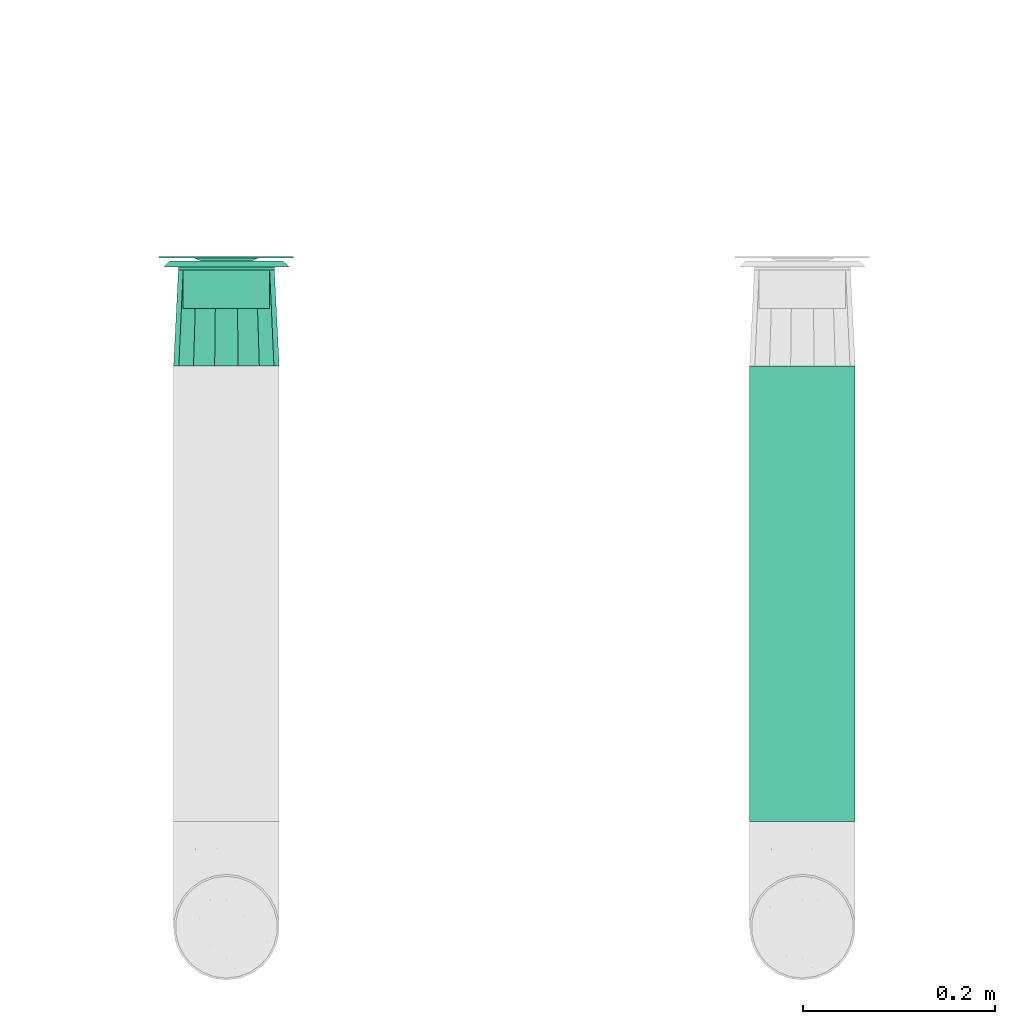
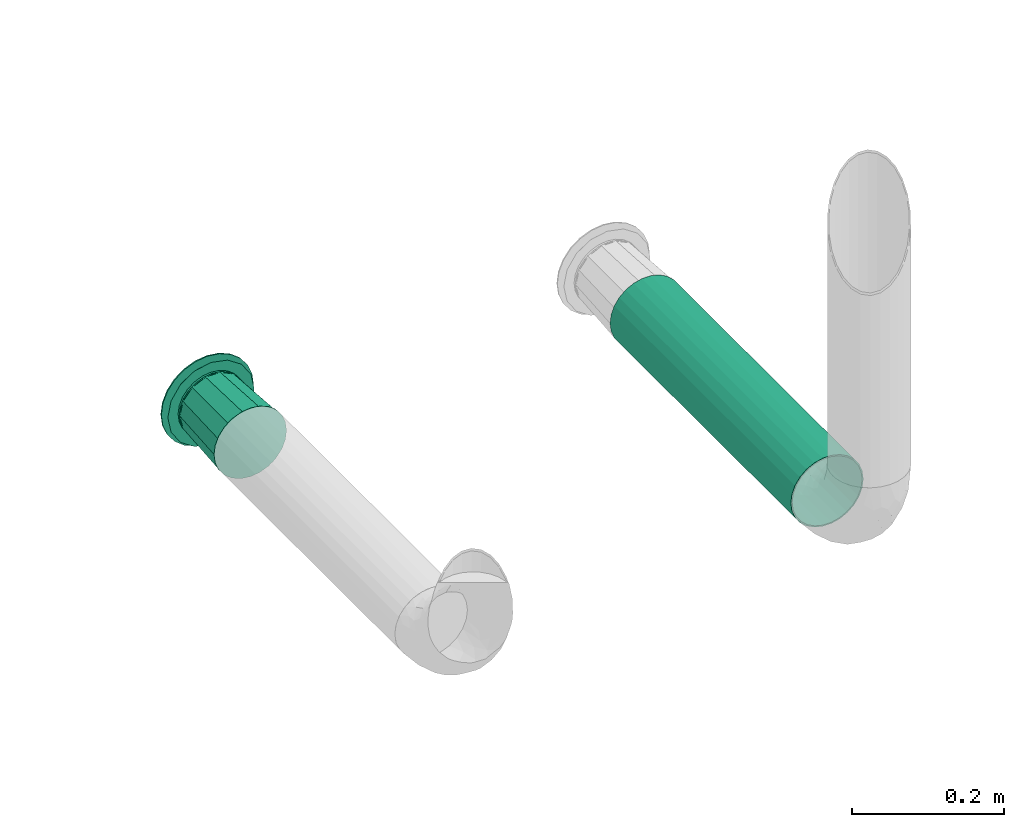
# One storey, part 24 of 115: 1 flow fitting, 1 flow segment, 1 flow terminal.
"""IFC2X3 building model written with IfcOpenShell, lengths in millimetres."""

import ifcopenshell
import ifcopenshell.guid

model = None  # the IFC model being written
_history = None  # IfcOwnerHistory: only IFC2X3 demands one
_inside = {}  # id of a spatial element -> (the spatial element, [elements in it])
_under = {}  # id of a project, library or spatial element -> (it, [spatial elements below it])
_declared = {}  # id of a project -> (the project, [libraries it declares])
_typed = {}  # id of a type object -> (the type object, [elements of that type])
_made_of = {}  # id of a material, layer set ... -> (it, [elements and type objects made of it])


def new_model(schema):
    """Start an empty IFC model of exactly this schema.

    Asked for "IFC4X3", IfcOpenShell would pick the latest addendum, in which some entities
    have other attributes; the version numbers below select the first issue.
    IFC2X3 requires an IfcOwnerHistory on every rooted entity: one is made here for all.
    """
    global model, _history
    if schema == "IFC4X3":
        model = ifcopenshell.file(schema_version=(4, 3, 0, 0))
    else:
        model = ifcopenshell.file(schema=schema)
    _inside.clear()
    _under.clear()
    _declared.clear()
    _typed.clear()
    _made_of.clear()
    _history = None
    if model.schema == "IFC2X3":
        org = make("IfcOrganization", Name="unknown")
        user = make(
            "IfcPersonAndOrganization",
            ThePerson=make("IfcPerson", FamilyName="unknown"),
            TheOrganization=org,
        )
        app = make(
            "IfcApplication",
            ApplicationDeveloper=org,
            Version="unknown",
            ApplicationFullName="unknown",
            ApplicationIdentifier="unknown",
        )
        _history = make(
            "IfcOwnerHistory",
            OwningUser=user,
            OwningApplication=app,
            ChangeAction="ADDED",
            CreationDate=0,
        )
    return model


def make(cls, **values):
    """One entity of the class cls with the attributes given. An attribute that is None is left unset."""
    return model.create_entity(
        cls, **{name: value for name, value in values.items() if value is not None}
    )


def entity(cls, *values):
    """Any entity or typed value of the class cls, its attributes in the order of the schema. None: left unset."""
    e = model.create_entity(cls)
    for i, value in enumerate(values):
        if value is not None:
            e[i] = value
    return e


def rooted(cls, **values):
    """An entity with a GlobalId (a new one), such as an element, a storey or a relation."""
    return make(cls, GlobalId=ifcopenshell.guid.new(), OwnerHistory=_history, **values)


def si_unit(unit_type, name, prefix=None):
    """IfcSIUnit, for example si_unit("LENGTHUNIT", "METRE", prefix="MILLI")."""
    return make("IfcSIUnit", UnitType=unit_type, Prefix=prefix, Name=name)


def converted_unit(unit_type, name, factor, base, dimensions=None, offset=None):
    """IfcConversionBasedUnit, such as the inch: factor (a typed value) times the base unit."""
    return make(
        "IfcConversionBasedUnit"
        if offset is None
        else "IfcConversionBasedUnitWithOffset",
        ConversionOffset=offset,
        Dimensions=None
        if dimensions is None
        else entity("IfcDimensionalExponents", *dimensions),
        UnitType=unit_type,
        Name=name,
        ConversionFactor=make(
            "IfcMeasureWithUnit", ValueComponent=factor, UnitComponent=base
        ),
    )


def derived_unit(unit_type, elements):
    """IfcDerivedUnit: a product of units, each with its exponent."""
    return make(
        "IfcDerivedUnit",
        Elements=[
            make("IfcDerivedUnitElement", Unit=unit, Exponent=power)
            for unit, power in elements
        ],
        UnitType=unit_type,
    )


def assignment(units):
    """IfcUnitAssignment: the units of a project."""
    return None if units is None else make("IfcUnitAssignment", Units=units)


def point(xyz):
    """IfcCartesianPoint."""
    return None if xyz is None else make("IfcCartesianPoint", Coordinates=xyz)


def direction(xyz):
    """IfcDirection."""
    return None if xyz is None else make("IfcDirection", DirectionRatios=xyz)


def frame(location, z_axis=None, x_axis=None):
    """IfcAxis2Placement3D, a coordinate frame: its origin and axes. An axis left out is left unset."""
    return make(
        "IfcAxis2Placement3D",
        Location=point(location),
        Axis=direction(z_axis),
        RefDirection=direction(x_axis),
    )


def frame_2d(location, x_axis=None):
    """IfcAxis2Placement2D, a coordinate frame in the plane: its origin and x axis."""
    return make(
        "IfcAxis2Placement2D", Location=point(location), RefDirection=direction(x_axis)
    )


def origin_with_axes():
    """The frame at (0, 0, 0) with the z axis (0, 0, 1) and the x axis (1, 0, 0) written out."""
    return frame((0.0, 0.0, 0.0), z_axis=(0.0, 0.0, 1.0), x_axis=(1.0, 0.0, 0.0))


def origin_2d_with_axis():
    """The frame at (0, 0) in the plane with the x axis (1, 0) written out."""
    return frame_2d((0.0, 0.0), x_axis=(1.0, 0.0))


def place(relative_to, where):
    """IfcLocalPlacement: puts the frame where relative to a parent placement (None: the world)."""
    return make(
        "IfcLocalPlacement", PlacementRelTo=relative_to, RelativePlacement=where
    )


def context(
    kind, dimensions, precision=None, world=None, true_north=None, identifier=None
):
    """IfcGeometricRepresentationContext, for example the 3D "Model" context."""
    return make(
        "IfcGeometricRepresentationContext",
        ContextIdentifier=identifier,
        ContextType=kind,
        CoordinateSpaceDimension=dimensions,
        Precision=precision,
        WorldCoordinateSystem=world,
        TrueNorth=true_north,
    )


def subcontext(parent, identifier, kind, view, scale=None):
    """IfcGeometricRepresentationSubContext, for example "Body" below "Model"."""
    return make(
        "IfcGeometricRepresentationSubContext",
        ContextIdentifier=identifier,
        ContextType=kind,
        ParentContext=parent,
        TargetScale=scale,
        TargetView=view,
    )


def project(units=None, contexts=None):
    """IfcProject with its units and contexts."""
    return rooted(
        "IfcProject",
        Name="project",
        RepresentationContexts=contexts,
        UnitsInContext=assignment(units),
    )


def spatial(cls, under=None, at=None, **own):
    """A site, building, storey or space (cls), placed at a placement, below another one or the project."""
    s = rooted(cls, ObjectPlacement=at, **own)
    if under is not None:
        _under.setdefault(under.id(), (under, []))[1].append(s)
    return s


def profile(cls, at=None, kind="AREA", **sizes):
    """A parametric profile (cls). Its sizes go by their IFC names, for example OverallWidth=200.0."""
    return make(cls, ProfileType=kind, Position=at, **sizes)


def hollow_circle(**sizes):
    """IfcCircleHollowProfileDef."""
    return profile("IfcCircleHollowProfileDef", **sizes)


def extrude(swept, where, along, depth):
    """IfcExtrudedAreaSolid: the profile swept, set in the frame where, extruded along a direction by depth."""
    return make(
        "IfcExtrudedAreaSolid",
        SweptArea=swept,
        Position=where,
        ExtrudedDirection=direction(along),
        Depth=depth,
    )


def faces_of(points, faces, orient=None, outer=None):
    """IfcFace entities. A face is a list of loops; a loop is a list of indices into points, from 0.

    orient and outer hold one flag for each loop. By default every Orientation is true, the
    first loop of a face is its IfcFaceOuterBound and the others are IfcFaceBound.
    """
    made = []
    for i, loops in enumerate(faces):
        bounds = []
        for j, loop in enumerate(loops):
            is_outer = j == 0 if outer is None else outer[i][j]
            bounds.append(
                make(
                    "IfcFaceOuterBound" if is_outer else "IfcFaceBound",
                    Bound=make("IfcPolyLoop", Polygon=[points[k] for k in loop]),
                    Orientation=True if orient is None else orient[i][j],
                )
            )
        made.append(make("IfcFace", Bounds=bounds))
    return made


def open_shell(faces, orient=None, outer=None):
    """The faces of one IfcOpenShell. surface_model builds it on its shared points."""
    return ("IfcOpenShell", faces, orient, outer)


def surface_model(cls, points, shells):
    """IfcFaceBasedSurfaceModel or IfcShellBasedSurfaceModel (cls): surfaces that need not close."""
    shared = [point(p) for p in points]
    made = [make(c, CfsFaces=faces_of(shared, fs, o, b)) for c, fs, o, b in shells]
    if cls == "IfcFaceBasedSurfaceModel":
        return make(cls, FbsmFaces=made)
    return make(cls, SbsmBoundary=made)


def shape(context_of_items, identifier, shape_type, items):
    """IfcShapeRepresentation: the items that make up one representation, for example the "Body"."""
    return make(
        "IfcShapeRepresentation",
        ContextOfItems=context_of_items,
        RepresentationIdentifier=identifier,
        RepresentationType=shape_type,
        Items=items,
    )


def source(mapping_origin, context_of_items, identifier, shape_type, items):
    """IfcRepresentationMap: a shape defined once, which mapped items show again and again."""
    return make(
        "IfcRepresentationMap",
        MappingOrigin=mapping_origin,
        MappedRepresentation=shape(context_of_items, identifier, shape_type, items),
    )


def transform(
    local_origin,
    x_axis=None,
    y_axis=None,
    z_axis=None,
    scale=None,
    scale2=None,
    scale3=None,
    uniform=True,
):
    """IfcCartesianTransformationOperator3D, or its non-uniform kind. x_axis, y_axis, z_axis: its Axis1, 2, 3."""
    if uniform:
        return make(
            "IfcCartesianTransformationOperator3D",
            Axis1=direction(x_axis),
            Axis2=direction(y_axis),
            LocalOrigin=point(local_origin),
            Scale=scale,
            Axis3=direction(z_axis),
        )
    return make(
        "IfcCartesianTransformationOperator3DnonUniform",
        Axis1=direction(x_axis),
        Axis2=direction(y_axis),
        LocalOrigin=point(local_origin),
        Scale=scale,
        Axis3=direction(z_axis),
        Scale2=scale2,
        Scale3=scale3,
    )


def mapped(mapping_source, mapping_target):
    """IfcMappedItem: shows the shape of a source again, moved by a transform."""
    return make(
        "IfcMappedItem", MappingSource=mapping_source, MappingTarget=mapping_target
    )


def material(Name=None, Category=None):
    """IfcMaterial."""
    return make("IfcMaterial", Name=Name, Category=Category)


def layer(
    of_material, thickness, ventilated=None, Name=None, Category=None, Priority=None
):
    """IfcMaterialLayer: one layer of a wall or slab, of a material (None: an air gap)."""
    return make(
        "IfcMaterialLayer",
        Material=of_material,
        LayerThickness=thickness,
        IsVentilated=ventilated,
        Name=Name,
        Category=Category,
        Priority=Priority,
    )


def layer_set(layers, Name=None):
    """IfcMaterialLayerSet."""
    return make("IfcMaterialLayerSet", MaterialLayers=layers, LayerSetName=Name)


def layer_usage(for_layer_set, set_direction, sense, offset, extent=None):
    """IfcMaterialLayerSetUsage: how a layer set lies in its element."""
    return make(
        "IfcMaterialLayerSetUsage",
        ForLayerSet=for_layer_set,
        LayerSetDirection=set_direction,
        DirectionSense=sense,
        OffsetFromReferenceLine=offset,
        ReferenceExtent=extent,
    )


def made_of(thing, what):
    """Note that an element or type object is made of a material, layer set ...; save() writes the relation."""
    if what is not None:
        _made_of.setdefault(what.id(), (what, []))[1].append(thing)
    return thing


def type_object(cls, material=None, **own):
    """A type object (cls), such as IfcWallType, which elements share."""
    return made_of(rooted(cls, **own), material)


def element(
    cls,
    number,
    at=None,
    inside=None,
    cuts=None,
    type_object=None,
    material=None,
    context=None,
    identifier="Body",
    shape_type=None,
    held_by="IfcProductDefinitionShape",
    body=None,
    shapes=None,
    **own,
):
    """One element of the class cls, such as IfcWall. Its Tag is "e" and its number.

    at: its placement. inside: the storey or other place that contains it. cuts: it is an
    opening in that element (IfcRelVoidsElement). A single representation is given by context,
    identifier, shape_type and body (its items); several are given by shapes. held_by: the class
    of the entity that holds the representations. save() writes the other relations.
    """
    e = rooted(cls, Tag="e%d" % number, ObjectPlacement=at, **own)
    if body is not None:
        shapes = [shape(context, identifier, shape_type, body)]
    if shapes is not None:
        e.Representation = make(held_by, Representations=shapes)
    if inside is not None:
        _inside.setdefault(inside.id(), (inside, []))[1].append(e)
    if cuts is not None:
        rooted(
            "IfcRelVoidsElement", RelatingBuildingElement=cuts, RelatedOpeningElement=e
        )
    if type_object is not None:
        _typed.setdefault(type_object.id(), (type_object, []))[1].append(e)
    return made_of(e, material)


def aggregate(whole, parts):
    """IfcRelAggregates: a whole, such as a stair, and the parts it consists of."""
    return rooted("IfcRelAggregates", RelatingObject=whole, RelatedObjects=parts)


def save(model, path):
    """Write the relations noted so far, then the file.

    IfcRelAggregates (storeys below a building ...), IfcRelContainedInSpatialStructure (elements
    in a storey), IfcRelDefinesByType, IfcRelAssociatesMaterial and IfcRelDeclares: one each for
    every whole, place, type object, material and project.
    """
    for whole, parts in _under.values():
        aggregate(whole, parts)
    for where, things in _inside.values():
        rooted(
            "IfcRelContainedInSpatialStructure",
            RelatedElements=things,
            RelatingStructure=where,
        )
    for kind, things in _typed.values():
        rooted("IfcRelDefinesByType", RelatedObjects=things, RelatingType=kind)
    for what, things in _made_of.values():
        rooted("IfcRelAssociatesMaterial", RelatedObjects=things, RelatingMaterial=what)
    for by, libraries in _declared.values():
        rooted("IfcRelDeclares", RelatingContext=by, RelatedDefinitions=libraries)
    model.write(path)


model = new_model("IFC2X3")

# Units and contexts
model_context = context("Model", 3, precision=1e-05, world=origin_with_axes(), true_north=direction((0.0, 1.0)))
body_context = subcontext(model_context, "Body", "Model", "MODEL_VIEW")
ifc_project = project(units=[si_unit("AREAUNIT", "SQUARE_METRE"), si_unit("VOLUMEUNIT", "CUBIC_METRE", prefix="DECI"), si_unit("TIMEUNIT", "SECOND"), si_unit("THERMODYNAMICTEMPERATUREUNIT", "DEGREE_CELSIUS"), si_unit("PRESSUREUNIT", "PASCAL"), si_unit("MASSUNIT", "GRAM", prefix="KILO"), si_unit("LENGTHUNIT", "METRE", prefix="MILLI"), si_unit("POWERUNIT", "WATT"), si_unit("ELECTRICCURRENTUNIT", "AMPERE"), si_unit("ELECTRICVOLTAGEUNIT", "VOLT"), derived_unit("VOLUMETRICFLOWRATEUNIT", [(si_unit("VOLUMEUNIT", "CUBIC_METRE", prefix="DECI"), 1), (si_unit("TIMEUNIT", "SECOND"), -1)]), derived_unit("LINEARVELOCITYUNIT", [(si_unit("LENGTHUNIT", "METRE"), 1), (si_unit("TIMEUNIT", "SECOND"), -1)]), derived_unit("MASSDENSITYUNIT", [(si_unit("MASSUNIT", "GRAM", prefix="KILO"), 1), (si_unit("VOLUMEUNIT", "CUBIC_METRE"), -1)]), converted_unit("PLANEANGLEUNIT", "DEGREE", entity("IfcRatioMeasure", 0.01745), si_unit("PLANEANGLEUNIT", "RADIAN"), dimensions=[0, 0, 0, 0, 0, 0, 0])], contexts=[model_context])

# Site, building, storey
site_placement = place(None, origin_with_axes())
site = spatial("IfcSite", under=ifc_project, at=site_placement, CompositionType="ELEMENT")
building_placement = place(site_placement, origin_with_axes())
building = spatial("IfcBuilding", under=site, at=building_placement, Name="mc-building", CompositionType="ELEMENT")
storey_placement = place(building_placement, frame((0.0, 0.0, 2950.0), z_axis=(0.0, 0.0, 1.0), x_axis=(1.0, 0.0, 0.0)))
storey = spatial("IfcBuildingStorey", under=building, at=storey_placement, Name="2. Korrus", CompositionType="ELEMENT", Elevation=2950.0)

# Flow terminal
air_terminal_type = type_object("IfcAirTerminalType", Name="100", PredefinedType="NOTDEFINED")
shared_shape_1 = source(origin_with_axes(), body_context, "Body", "SurfaceModel", [
    surface_model("IfcShellBasedSurfaceModel", [(11.2, 18.11733, -67.61481), (11.2, -18.11733, -67.61481), (11.2, 0.0, -70.0), (11.2, 67.61481, -18.11733), (11.2, 35.0, -60.62178), (11.2, 49.49747, -49.49747), (11.2, 60.62178, -35.0), (11.2, -67.61481, 18.11733), (11.2, -49.49747, -49.49747), (11.2, -67.61481, -18.11733), (11.2, -35.0, -60.62178), (11.2, -60.62178, -35.0), (11.2, -70.0, 0.0), (11.2, 18.11733, 67.61481), (11.2, 70.0, 0.0), (11.2, 67.61481, 18.11733), (11.2, 49.49747, 49.49747), (11.2, 60.62178, 35.0), (11.2, 35.0, 60.62178), (11.2, -49.49747, 49.49747), (11.2, -60.62178, 35.0), (11.2, -35.0, 60.62178), (11.2, -18.11733, 67.61481), (11.2, 0.0, 70.0), (9.2, 18.11733, 67.61481), (9.2, -67.61481, 18.11733), (9.2, 0.0, 70.0), (9.2, 49.49747, 49.49747), (9.2, 35.0, 60.62178), (9.2, 60.62178, 35.0), (9.2, 67.61481, 18.11733), (9.2, -35.0, 60.62178), (9.2, -49.49747, 49.49747), (9.2, -18.11733, 67.61481), (9.2, -60.62178, 35.0), (9.2, -67.61481, -18.11733), (9.2, -70.0, 0.0), (9.2, 67.61481, -18.11733), (9.2, 18.11733, -67.61481), (9.2, 49.49747, -49.49747), (9.2, 60.62178, -35.0), (9.2, 35.0, -60.62178), (9.2, -18.11733, -67.61481), (9.2, -49.49747, -49.49747), (9.2, -60.62178, -35.0), (9.2, -35.0, -60.62178), (9.2, 0.0, -70.0), (9.2, 70.0, 0.0), (9.2, 32.75, 0.0), (9.2, -16.375, 28.36233), (9.2, -28.36233, 16.375), (9.2, 16.375, 28.36233), (9.2, 0.0, 32.75), (9.2, 28.36233, 16.375), (9.2, -32.75, 0.0), (9.2, -16.375, -28.36233), (9.2, 16.375, -28.36233), (9.2, 0.0, -32.75), (9.2, 28.36233, -16.375), (9.2, -28.36233, -16.375), (6.2, -21.19625, -15.39997), (6.2, -21.19625, 15.39997), (6.2, 8.09625, 24.91768), (6.2, -8.09625, 24.91768), (6.2, -26.2, 0.0), (6.2, 21.19625, 15.39997), (6.2, -8.09625, -24.91768), (6.2, 21.19625, -15.39997), (6.2, 8.09625, -24.91768), (6.2, 26.2, 0.0), (9.2, 31.06579, -6.28555), (6.2, 23.69812, -7.69999), (6.2, -14.64625, -20.15883), (9.2, -22.36867, -22.36867), (6.2, -23.69812, -7.69999), (9.2, -31.06579, -6.28555), (6.2, 14.64625, -20.15883), (9.2, 8.1875, -30.55617), (6.2, 0.0, -24.91768), (9.2, 22.36867, -22.36867), (9.2, -8.1875, -30.55617), (9.2, -31.06579, 6.28555), (6.2, -23.69812, 7.69999), (6.2, 14.64625, 20.15883), (9.2, 22.36867, 22.36867), (6.2, 23.69812, 7.69999), (9.2, 31.06579, 6.28555), (6.2, -14.64625, 20.15883), (9.2, -8.1875, 30.55617), (6.2, 0.0, 24.91768), (9.2, -22.36867, 22.36867), (9.2, 8.1875, 30.55617), (6.2, -13.11761, 57.472), (6.2, -36.75472, 46.08897), (6.2, -53.11211, 25.57744), (6.2, 36.75472, 46.08897), (6.2, -58.95, 0.0), (6.2, 13.11761, 57.472), (6.2, 53.11211, 25.57744), (6.2, -53.11211, -25.57744), (6.2, -36.75472, -46.08897), (6.2, -13.11761, -57.472), (6.2, 58.95, 0.0), (6.2, 53.11211, -25.57744), (6.2, 13.11761, -57.472), (6.2, 36.75472, -46.08897), (0.0, -60.51411, 25.06576), (0.0, 0.0, 65.5), (0.0, 25.06576, 60.51411), (0.0, 46.3155, 46.3155), (0.0, 60.51411, 25.06576), (0.0, -46.3155, 46.3155), (0.0, -25.06576, 60.51411), (0.0, 0.0, -65.5), (0.0, -65.5, 0.0), (0.0, 65.5, 0.0), (0.0, 60.51411, -25.06576), (0.0, 46.3155, -46.3155), (0.0, 25.06576, -60.51411), (0.0, -46.3155, -46.3155), (0.0, -60.51411, -25.06576), (0.0, -25.06576, -60.51411), (6.2, 56.03105, -12.78872), (0.0, 53.4148, -35.69063), (0.0, 35.69063, -53.4148), (6.2, 24.93616, -51.78048), (0.0, -12.53288, -63.00706), (6.2, 0.0, -57.472), (0.0, -35.69063, -53.4148), (0.0, 63.00706, -12.53288), (6.2, 44.93342, -35.83321), (6.2, -24.93616, -51.78048), (6.2, -44.93342, -35.83321), (0.0, -53.4148, -35.69063), (0.0, 12.53288, -63.00706), (6.2, -56.03105, -12.78872), (0.0, -63.00706, -12.53288), (6.2, -56.03105, 12.78872), (0.0, -53.4148, 35.69063), (0.0, -35.69063, 53.4148), (6.2, -24.93616, 51.78048), (0.0, 12.53288, 63.00706), (6.2, 0.0, 57.472), (0.0, 35.69063, 53.4148), (0.0, -63.00706, 12.53288), (6.2, -44.93342, 35.83321), (6.2, 24.93616, 51.78048), (6.2, 44.93342, 35.83321), (0.0, 53.4148, 35.69063), (0.0, -12.53288, 63.00706), (6.2, 56.03105, 12.78872), (0.0, 63.00706, 12.53288), (-3.1, 12.94095, 48.29629), (-3.1, -35.35534, 35.35534), (-3.1, 0.0, 50.0), (-3.1, 35.35534, 35.35534), (-3.1, 25.0, 43.30127), (-3.1, -43.30127, 25.0), (-3.1, 43.30127, 25.0), (-3.1, -48.29629, -12.94095), (-3.1, -12.94095, 48.29629), (-3.1, -25.0, 43.30127), (-3.1, -50.0, 0.0), (-3.1, -48.29629, 12.94095), (-3.1, 48.29629, 12.94095), (-3.1, 12.94095, -48.29629), (-3.1, 50.0, 0.0), (-3.1, 48.29629, -12.94095), (-3.1, 35.35534, -35.35534), (-3.1, 43.30127, -25.0), (-3.1, 25.0, -43.30127), (-3.1, 0.0, -50.0), (-3.1, -35.35534, -35.35534), (-3.1, -43.30127, -25.0), (-3.1, -25.0, -43.30127), (-3.1, -12.94095, -48.29629), (0.0, 25.0, -43.30127), (0.0, 0.0, -50.0), (0.0, 12.94095, -48.29629), (0.0, 48.29629, -12.94095), (0.0, 35.35534, -35.35534), (0.0, -25.0, -43.30127), (0.0, 43.30127, -25.0), (0.0, -50.0, 0.0), (0.0, -12.94095, -48.29629), (0.0, -35.35534, -35.35534), (0.0, -48.29629, -12.94095), (0.0, -43.30127, -25.0), (0.0, 50.0, 0.0), (0.0, 43.30127, 25.0), (0.0, 12.94095, 48.29629), (0.0, 35.35534, 35.35534), (0.0, 25.0, 43.30127), (0.0, 0.0, 50.0), (0.0, -35.35534, 35.35534), (0.0, -43.30127, 25.0), (0.0, -48.29629, 12.94095), (0.0, -12.94095, 48.29629), (0.0, -25.0, 43.30127), (0.0, 48.29629, 12.94095), (-43.1, 0.0, 45.0), (-43.1, 11.64686, 43.46666), (-43.1, 22.5, 38.97115), (-43.1, -11.64686, 43.46666), (-43.1, 38.97115, 22.5), (-43.1, 43.46666, 11.64686), (-43.1, 31.81981, 31.81981), (-43.1, -22.5, 38.97115), (-43.1, -43.46666, 11.64686), (-43.1, -31.81981, 31.81981), (-43.1, -38.97115, 22.5), (-43.1, -45.0, 0.0), (-43.1, -43.46666, -11.64686), (-43.1, 45.0, 0.0), (-43.1, 43.46666, -11.64686), (-43.1, 38.97115, -22.5), (-43.1, 31.81981, -31.81981), (-43.1, 22.5, -38.97115), (-43.1, 11.64686, -43.46666), (-43.1, -31.81981, -31.81981), (-43.1, -38.97115, -22.5), (-43.1, -22.5, -38.97115), (-43.1, 0.0, -45.0), (-43.1, -11.64686, -43.46666), (-3.1, 22.5, -38.97115), (-3.1, 0.0, -45.0), (-3.1, 11.64686, -43.46666), (-3.1, 31.81981, -31.81981), (-3.1, -22.5, -38.97115), (-3.1, 38.97115, -22.5), (-3.1, 43.46666, -11.64686), (-3.1, 45.0, 0.0), (-3.1, -45.0, 0.0), (-3.1, -11.64686, -43.46666), (-3.1, -31.81981, -31.81981), (-3.1, -43.46666, -11.64686), (-3.1, -38.97115, -22.5), (-3.1, 0.0, 45.0), (-3.1, 43.46666, 11.64686), (-3.1, 38.97115, 22.5), (-3.1, 22.5, 38.97115), (-3.1, 31.81981, 31.81981), (-3.1, 11.64686, 43.46666), (-3.1, -11.64686, 43.46666), (-3.1, -43.46666, 11.64686), (-3.1, -31.81981, 31.81981), (-3.1, -38.97115, 22.5), (-3.1, -22.5, 38.97115)], [open_shell([[[0, 1, 2]], [[3, 0, 4]], [[5, 6, 3]], [[5, 3, 4]], [[7, 1, 0]], [[8, 7, 9]], [[10, 7, 8]], [[8, 9, 11]], [[12, 9, 7]], [[1, 7, 10]], [[7, 0, 3]], [[13, 14, 15]], [[16, 15, 17]], [[16, 18, 13]], [[16, 13, 15]], [[14, 13, 7]], [[7, 19, 20]], [[19, 7, 21]], [[7, 22, 21]], [[22, 7, 23]], [[7, 13, 23]], [[14, 7, 3]], [[24, 25, 26]], [[27, 24, 28]], [[27, 29, 30]], [[27, 30, 24]], [[25, 24, 30]], [[31, 25, 32]], [[25, 31, 33]], [[32, 25, 34]], [[33, 26, 25]], [[25, 35, 36]], [[25, 30, 37]], [[25, 37, 38]], [[39, 37, 40]], [[39, 41, 38]], [[39, 38, 37]], [[38, 42, 25]], [[35, 43, 44]], [[35, 25, 43]], [[45, 43, 25]], [[42, 45, 25]], [[38, 46, 42]], [[37, 30, 47]], [[35, 9, 36]], [[44, 11, 35]], [[10, 43, 45]], [[44, 43, 8]], [[1, 45, 42]], [[35, 11, 9]], [[9, 12, 36]], [[1, 10, 45]], [[8, 43, 10]], [[8, 11, 44]], [[2, 1, 42]], [[42, 46, 2]], [[38, 0, 46]], [[41, 4, 38]], [[6, 39, 40]], [[41, 39, 5]], [[3, 40, 37]], [[41, 5, 4]], [[4, 0, 38]], [[14, 3, 37]], [[6, 40, 3]], [[6, 5, 39]], [[47, 14, 37]], [[46, 0, 2]], [[30, 15, 47]], [[29, 17, 30]], [[18, 27, 28]], [[29, 27, 16]], [[13, 28, 24]], [[30, 17, 15]], [[15, 14, 47]], [[13, 18, 28]], [[16, 27, 18]], [[16, 17, 29]], [[23, 13, 24]], [[24, 26, 23]], [[33, 22, 26]], [[31, 21, 33]], [[20, 32, 34]], [[31, 32, 19]], [[7, 34, 25]], [[31, 19, 21]], [[21, 22, 33]], [[12, 7, 25]], [[20, 34, 7]], [[20, 19, 32]], [[36, 12, 25]], [[26, 22, 23]], [[48, 49, 50]], [[48, 51, 49]], [[49, 51, 52]], [[53, 51, 48]], [[48, 50, 54]], [[54, 55, 48]], [[56, 55, 57]], [[55, 58, 48]], [[58, 55, 56]], [[55, 54, 59]], [[60, 61, 62]], [[62, 61, 63]], [[64, 61, 60]], [[62, 65, 66]], [[67, 68, 65]], [[66, 60, 62]], [[65, 68, 66]], [[69, 67, 65]], [[69, 48, 70]], [[58, 71, 70]], [[72, 73, 60]], [[59, 74, 60]], [[75, 64, 74]], [[56, 68, 76]], [[72, 66, 55]], [[73, 72, 55]], [[68, 77, 78]], [[64, 75, 54]], [[59, 75, 74]], [[70, 71, 69]], [[67, 79, 76]], [[80, 55, 66]], [[68, 56, 77]], [[56, 76, 79]], [[79, 67, 58]], [[71, 58, 67]], [[80, 78, 57]], [[77, 57, 78]], [[66, 78, 80]], [[59, 60, 73]], [[64, 54, 81]], [[50, 82, 81]], [[83, 84, 65]], [[53, 85, 65]], [[86, 69, 85]], [[49, 63, 87]], [[83, 62, 51]], [[84, 83, 51]], [[63, 88, 89]], [[69, 86, 48]], [[53, 86, 85]], [[81, 82, 64]], [[61, 90, 87]], [[91, 51, 62]], [[63, 49, 88]], [[49, 87, 90]], [[90, 61, 50]], [[82, 50, 61]], [[91, 89, 52]], [[88, 52, 89]], [[62, 89, 91]], [[53, 65, 84]], [[92, 93, 94]], [[95, 94, 96]], [[97, 92, 95]], [[95, 92, 94]], [[96, 98, 95]], [[96, 99, 98]], [[99, 100, 101]], [[101, 102, 98]], [[102, 101, 103]], [[104, 105, 103]], [[101, 104, 103]], [[101, 98, 99]], [[106, 107, 108]], [[109, 110, 108]], [[106, 108, 110]], [[111, 112, 106]], [[106, 112, 107]], [[106, 113, 114]], [[106, 110, 113]], [[115, 116, 117]], [[117, 113, 110]], [[113, 117, 118]], [[114, 119, 120]], [[121, 119, 114]], [[121, 114, 113]], [[115, 117, 110]], [[103, 116, 122]], [[123, 116, 103]], [[124, 125, 118]], [[101, 126, 127]], [[100, 119, 128]], [[102, 122, 129]], [[103, 130, 123]], [[102, 129, 115]], [[113, 127, 126]], [[125, 124, 105]], [[130, 105, 117]], [[118, 125, 104]], [[124, 117, 105]], [[131, 100, 128]], [[119, 100, 132]], [[133, 99, 120]], [[134, 118, 104]], [[122, 116, 129]], [[127, 134, 104]], [[131, 121, 101]], [[99, 133, 132]], [[128, 121, 131]], [[130, 117, 123]], [[101, 121, 126]], [[99, 135, 120]], [[96, 136, 135]], [[136, 120, 135]], [[134, 127, 113]], [[133, 119, 132]], [[136, 96, 114]], [[94, 106, 137]], [[138, 106, 94]], [[139, 140, 112]], [[97, 141, 142]], [[95, 109, 143]], [[96, 137, 144]], [[94, 145, 138]], [[96, 144, 114]], [[107, 142, 141]], [[140, 139, 93]], [[145, 93, 111]], [[112, 140, 92]], [[139, 111, 93]], [[146, 95, 143]], [[109, 95, 147]], [[148, 98, 110]], [[149, 112, 92]], [[137, 106, 144]], [[142, 149, 92]], [[146, 108, 97]], [[98, 148, 147]], [[143, 108, 146]], [[145, 111, 138]], [[97, 108, 141]], [[98, 150, 110]], [[102, 151, 150]], [[151, 110, 150]], [[149, 142, 107]], [[148, 109, 147]], [[151, 102, 115]], [[152, 153, 154]], [[155, 152, 156]], [[157, 152, 158]], [[158, 152, 155]], [[158, 159, 157]], [[160, 153, 161]], [[160, 154, 153]], [[157, 162, 163]], [[153, 152, 157]], [[157, 159, 162]], [[158, 164, 159]], [[165, 166, 167]], [[168, 167, 169]], [[170, 165, 167]], [[170, 167, 168]], [[166, 165, 171]], [[159, 172, 173]], [[172, 159, 174]], [[174, 171, 175]], [[159, 164, 174]], [[166, 171, 174]], [[174, 164, 166]], [[176, 177, 178]], [[179, 176, 180]], [[176, 179, 181]], [[179, 180, 182]], [[179, 183, 181]], [[177, 181, 184]], [[177, 176, 181]], [[185, 186, 187]], [[186, 185, 181]], [[181, 183, 186]], [[183, 179, 188]], [[183, 188, 189]], [[190, 189, 191]], [[189, 190, 183]], [[190, 191, 192]], [[193, 194, 190]], [[183, 195, 196]], [[183, 190, 195]], [[194, 197, 198]], [[194, 195, 190]], [[197, 194, 193]], [[189, 188, 199]], [[164, 199, 166]], [[158, 189, 164]], [[192, 155, 156]], [[158, 155, 191]], [[190, 156, 152]], [[164, 189, 199]], [[199, 188, 166]], [[190, 192, 156]], [[191, 155, 192]], [[191, 189, 158]], [[193, 190, 152]], [[152, 154, 193]], [[160, 197, 154]], [[161, 198, 160]], [[195, 153, 157]], [[161, 153, 194]], [[196, 157, 163]], [[161, 194, 198]], [[198, 197, 160]], [[183, 196, 163]], [[195, 157, 196]], [[195, 194, 153]], [[162, 183, 163]], [[154, 197, 193]], [[159, 186, 162]], [[173, 187, 159]], [[181, 172, 174]], [[173, 172, 185]], [[184, 174, 175]], [[159, 187, 186]], [[186, 183, 162]], [[184, 181, 174]], [[185, 172, 181]], [[185, 187, 173]], [[177, 184, 175]], [[175, 171, 177]], [[165, 178, 171]], [[170, 176, 165]], [[182, 168, 169]], [[170, 168, 180]], [[179, 169, 167]], [[170, 180, 176]], [[176, 178, 165]], [[188, 179, 167]], [[182, 169, 179]], [[182, 180, 168]], [[166, 188, 167]], [[171, 178, 177]], [[200, 201, 202]], [[203, 200, 202]], [[204, 205, 202]], [[204, 202, 206]], [[203, 202, 205]], [[207, 208, 209]], [[207, 203, 205]], [[209, 208, 210]], [[211, 208, 212]], [[208, 207, 212]], [[207, 205, 212]], [[213, 214, 215]], [[205, 215, 212]], [[212, 216, 217]], [[216, 212, 215]], [[218, 219, 217]], [[212, 219, 220]], [[212, 217, 219]], [[221, 222, 223]], [[222, 221, 219]], [[218, 222, 219]], [[215, 205, 213]], [[224, 225, 226]], [[227, 228, 224]], [[229, 230, 231]], [[228, 227, 229]], [[229, 232, 228]], [[225, 228, 233]], [[225, 224, 228]], [[234, 235, 236]], [[235, 234, 228]], [[228, 232, 235]], [[232, 229, 231]], [[237, 238, 239]], [[240, 239, 241]], [[240, 242, 237]], [[240, 237, 239]], [[238, 237, 243]], [[244, 245, 246]], [[247, 244, 232]], [[244, 247, 245]], [[232, 238, 247]], [[238, 243, 247]], [[238, 232, 231]], [[205, 238, 213]], [[204, 239, 205]], [[240, 206, 202]], [[204, 206, 241]], [[242, 202, 201]], [[205, 239, 238]], [[238, 231, 213]], [[240, 202, 242]], [[241, 206, 240]], [[241, 239, 204]], [[201, 237, 242]], [[201, 200, 237]], [[243, 203, 207]], [[209, 247, 207]], [[246, 210, 208]], [[209, 210, 245]], [[244, 208, 211]], [[203, 243, 200]], [[207, 247, 243]], [[200, 243, 237]], [[209, 245, 247]], [[210, 246, 245]], [[244, 246, 208]], [[211, 232, 244]], [[212, 235, 211]], [[220, 236, 212]], [[228, 219, 221]], [[220, 219, 234]], [[233, 221, 223]], [[212, 236, 235]], [[235, 232, 211]], [[233, 228, 221]], [[234, 219, 228]], [[234, 236, 220]], [[225, 233, 223]], [[223, 222, 225]], [[226, 218, 217]], [[216, 224, 217]], [[229, 215, 214]], [[216, 215, 227]], [[230, 214, 213]], [[218, 226, 222]], [[217, 224, 226]], [[222, 226, 225]], [[216, 227, 224]], [[215, 229, 227]], [[230, 229, 214]], [[213, 231, 230]]])]),
])
flow_terminal_placement = place(storey_placement, frame((12053.05418, 0.0, 2300.0), z_axis=(0.0, 0.0, 1.0), x_axis=(0.0, 1.0, 0.0)))
element("IfcFlowTerminal", 1, at=flow_terminal_placement, inside=storey, type_object=air_terminal_type, Name="100", context=body_context, shape_type="MappedRepresentation", body=[
    mapped(shared_shape_1, transform((0.0, 0.0, 0.0), scale=1.0)),
])

# Flow fitting
duct_fitting_type = type_object("IfcDuctFittingType", PredefinedType="TRANSITION")
shared_shape_2 = source(origin_with_axes(), body_context, "Body", "SurfaceModel", [
    surface_model("IfcShellBasedSurfaceModel", [(0.0, 12.94095, 48.29629), (0.0, -35.35534, 35.35534), (0.0, 0.0, 50.0), (0.0, 35.35534, 35.35534), (0.0, 25.0, 43.30127), (0.0, 43.30127, 25.0), (0.0, 48.29629, 12.94095), (0.0, -12.94095, 48.29629), (0.0, -25.0, 43.30127), (0.0, -48.29629, 12.94095), (0.0, -43.30127, 25.0), (0.0, -25.0, -43.30127), (0.0, -48.29629, -12.94095), (0.0, -50.0, 0.0), (0.0, 48.29629, -12.94095), (0.0, 12.94095, -48.29629), (0.0, 43.30127, -25.0), (0.0, 35.35534, -35.35534), (0.0, 25.0, -43.30127), (0.0, -35.35534, -35.35534), (0.0, -43.30127, -25.0), (0.0, -12.94095, -48.29629), (0.0, 0.0, -50.0), (0.0, 50.0, 0.0), (100.0, -55.0, 0.0), (100.0, -12.23865, 53.62104), (100.0, -34.29194, 43.00073), (100.0, 49.55329, -23.86361), (100.0, 12.23865, 53.62104), (100.0, 34.29194, 43.00073), (100.0, 55.0, 0.0), (100.0, 49.55329, 23.86361), (100.0, -49.55329, 23.86361), (100.0, 12.23865, -53.62104), (100.0, -49.55329, -23.86361), (100.0, -34.29194, -43.00073), (100.0, 34.29194, -43.00073), (100.0, -12.23865, -53.62104), (0.0, 11.12605, 48.7464), (0.0, -11.12605, 48.7464), (0.0, 31.17449, 39.09157), (0.0, -45.04844, -21.69419), (0.0, -45.04844, 21.69419), (0.0, -31.17449, 39.09157), (0.0, 45.04844, 21.69419), (0.0, 45.04844, -21.69419), (0.0, 31.17449, -39.09157), (0.0, -31.17449, -39.09157), (0.0, -11.12605, -48.7464), (0.0, 11.12605, -48.7464), (0.0, -47.52422, -10.84709), (100.0, -41.92261, -33.43217), (0.0, -38.11147, -30.39288), (100.0, 41.92261, -33.43217), (0.0, 38.11147, -30.39288), (0.0, -21.15027, -43.91899), (100.0, -23.2653, -48.31088), (100.0, -52.32388, -11.72483), (100.0, 0.0, -53.62104), (0.0, 0.0, -48.7464), (100.0, 23.2653, -48.31088), (0.0, 21.15027, -43.91899), (100.0, 52.32388, -11.72483), (0.0, 47.52422, -10.84709), (0.0, 47.52422, 10.84709), (100.0, 41.92261, 33.43217), (0.0, 38.11147, 30.39288), (100.0, -41.92261, 33.43217), (0.0, -38.11147, 30.39288), (0.0, 21.15027, 43.91899), (100.0, 23.2653, 48.31088), (100.0, 52.32388, 11.72483), (100.0, 0.0, 53.62104), (0.0, 0.0, 48.7464), (100.0, -23.2653, 48.31088), (0.0, -21.15027, 43.91899), (100.0, -52.32388, 11.72483), (0.0, -47.52422, 10.84709), (100.0, 27.5, -47.63139), (100.0, 0.0, -55.0), (100.0, 14.23505, -53.12592), (100.0, 38.89087, -38.89087), (100.0, -27.5, -47.63139), (100.0, 47.63139, -27.5), (100.0, 53.12592, -14.23505), (100.0, -14.23505, -53.12592), (100.0, -47.63139, -27.5), (100.0, -38.89087, -38.89087), (100.0, -53.12592, -14.23505), (100.0, 53.12592, 14.23505), (100.0, 47.63139, 27.5), (100.0, 27.5, 47.63139), (100.0, 38.89087, 38.89087), (100.0, 14.23505, 53.12592), (100.0, 0.0, 55.0), (100.0, -47.63139, 27.5), (100.0, -53.12592, 14.23505), (100.0, -27.5, 47.63139), (100.0, -38.89087, 38.89087), (100.0, -14.23505, 53.12592), (98.0, 0.0, 55.0), (98.0, 14.23505, 53.12592), (98.0, 27.5, 47.63139), (98.0, 38.89087, 38.89087), (98.0, 47.63139, 27.5), (98.0, -47.63139, 27.5), (98.0, 53.12592, -14.23505), (98.0, -27.5, 47.63139), (98.0, -14.23505, 53.12592), (98.0, -38.89087, 38.89087), (98.0, -55.0, 0.0), (98.0, -53.12592, 14.23505), (98.0, 53.12592, 14.23505), (98.0, 47.63139, -27.5), (98.0, -27.5, -47.63139), (98.0, 0.0, -55.0), (98.0, 38.89087, -38.89087), (98.0, 27.5, -47.63139), (98.0, 14.23505, -53.12592), (98.0, -47.63139, -27.5), (98.0, -38.89087, -38.89087), (98.0, -53.12592, -14.23505), (98.0, -14.23505, -53.12592), (98.0, 55.0, 0.0), (2.0, 12.94095, -48.29629), (2.0, 25.0, -43.30127), (2.0, 35.35534, -35.35534), (2.0, 43.30127, -25.0), (2.0, 48.29629, -12.94095), (2.0, 0.0, -50.0), (2.0, 50.0, 0.0), (2.0, -25.0, -43.30127), (2.0, -12.94095, -48.29629), (2.0, -35.35534, -35.35534), (2.0, -48.29629, -12.94095), (2.0, -43.30127, -25.0), (2.0, -48.29629, 12.94095), (2.0, 48.29629, 12.94095), (2.0, 43.30127, 25.0), (2.0, 35.35534, 35.35534), (2.0, -35.35534, 35.35534), (2.0, 12.94095, 48.29629), (2.0, 25.0, 43.30127), (2.0, 0.0, 50.0), (2.0, -43.30127, 25.0), (2.0, -50.0, 0.0), (2.0, -12.94095, 48.29629), (2.0, -25.0, 43.30127)], [open_shell([[[0, 1, 2]], [[3, 0, 4]], [[3, 5, 6]], [[0, 3, 1]], [[6, 1, 3]], [[7, 1, 8]], [[7, 2, 1]], [[1, 9, 10]], [[9, 1, 11]], [[12, 13, 9]], [[11, 1, 6]], [[6, 14, 11]], [[15, 14, 16]], [[17, 18, 15]], [[17, 15, 16]], [[11, 14, 15]], [[12, 19, 20]], [[19, 12, 11]], [[15, 21, 11]], [[12, 9, 11]], [[22, 21, 15]], [[14, 6, 23]], [[24, 25, 26]], [[25, 27, 28]], [[29, 28, 27]], [[27, 30, 31]], [[31, 29, 27]], [[24, 26, 32]], [[33, 24, 34]], [[33, 34, 35]], [[36, 27, 33]], [[33, 27, 24]], [[35, 37, 33]], [[24, 27, 25]], [[38, 23, 39]], [[40, 23, 38]], [[41, 42, 43]], [[41, 13, 42]], [[23, 43, 39]], [[40, 44, 23]], [[41, 23, 45]], [[41, 45, 46]], [[47, 41, 48]], [[49, 48, 41]], [[41, 46, 49]], [[23, 41, 43]], [[34, 50, 41]], [[47, 51, 52]], [[45, 27, 53]], [[36, 54, 53]], [[55, 48, 56]], [[34, 57, 50]], [[57, 13, 50]], [[13, 57, 24]], [[55, 35, 47]], [[35, 51, 47]], [[51, 41, 52]], [[58, 59, 49]], [[60, 61, 46]], [[37, 59, 58]], [[62, 63, 23]], [[35, 55, 56]], [[23, 30, 62]], [[53, 54, 45]], [[48, 37, 56]], [[33, 49, 61]], [[49, 33, 58]], [[54, 36, 46]], [[63, 27, 45]], [[34, 41, 51]], [[33, 61, 60]], [[48, 59, 37]], [[27, 63, 62]], [[46, 36, 60]], [[31, 64, 44]], [[40, 65, 66]], [[42, 32, 67]], [[26, 68, 67]], [[69, 38, 70]], [[31, 71, 64]], [[71, 23, 64]], [[23, 71, 30]], [[69, 29, 40]], [[29, 65, 40]], [[65, 44, 66]], [[72, 73, 39]], [[74, 75, 43]], [[28, 73, 72]], [[76, 77, 13]], [[29, 69, 70]], [[13, 24, 76]], [[67, 68, 42]], [[38, 28, 70]], [[25, 39, 75]], [[39, 25, 72]], [[68, 26, 43]], [[77, 32, 42]], [[31, 44, 65]], [[25, 75, 74]], [[38, 73, 28]], [[32, 77, 76]], [[43, 26, 74]], [[78, 79, 80]], [[81, 82, 78]], [[82, 83, 84]], [[81, 83, 82]], [[30, 82, 84]], [[79, 82, 85]], [[79, 78, 82]], [[82, 86, 87]], [[82, 30, 86]], [[24, 88, 86]], [[86, 30, 89]], [[90, 24, 89]], [[91, 90, 92]], [[91, 93, 94]], [[90, 91, 24]], [[94, 95, 91]], [[24, 95, 96]], [[24, 91, 95]], [[94, 97, 98]], [[98, 95, 94]], [[97, 94, 99]], [[89, 24, 86]], [[100, 101, 102]], [[100, 102, 103]], [[100, 104, 105]], [[104, 100, 103]], [[106, 105, 104]], [[100, 107, 108]], [[100, 109, 107]], [[105, 110, 111]], [[109, 100, 105]], [[105, 106, 110]], [[106, 104, 112]], [[106, 113, 110]], [[113, 114, 110]], [[115, 116, 117]], [[113, 116, 115]], [[117, 118, 115]], [[119, 114, 120]], [[121, 110, 119]], [[114, 115, 122]], [[119, 110, 114]], [[115, 114, 113]], [[123, 106, 112]], [[121, 88, 110]], [[119, 86, 121]], [[82, 120, 114]], [[119, 120, 87]], [[85, 114, 122]], [[121, 86, 88]], [[88, 24, 110]], [[85, 82, 114]], [[87, 120, 82]], [[87, 86, 119]], [[79, 85, 122]], [[122, 115, 79]], [[118, 80, 115]], [[117, 78, 118]], [[83, 116, 113]], [[117, 116, 81]], [[84, 113, 106]], [[117, 81, 78]], [[78, 80, 118]], [[30, 84, 106]], [[83, 113, 84]], [[83, 81, 116]], [[123, 30, 106]], [[115, 80, 79]], [[112, 89, 123]], [[104, 90, 112]], [[91, 103, 102]], [[104, 103, 92]], [[93, 102, 101]], [[112, 90, 89]], [[89, 30, 123]], [[93, 91, 102]], [[92, 103, 91]], [[92, 90, 104]], [[94, 93, 101]], [[101, 100, 94]], [[108, 99, 100]], [[107, 97, 108]], [[95, 109, 105]], [[107, 109, 98]], [[96, 105, 111]], [[107, 98, 97]], [[97, 99, 108]], [[24, 96, 111]], [[95, 105, 96]], [[95, 98, 109]], [[110, 24, 111]], [[100, 99, 94]], [[124, 125, 126]], [[124, 126, 127]], [[124, 128, 129]], [[128, 124, 127]], [[129, 128, 130]], [[129, 131, 132]], [[129, 130, 131]], [[133, 134, 135]], [[134, 133, 131]], [[131, 136, 134]], [[131, 130, 137]], [[137, 138, 139]], [[140, 137, 139]], [[140, 139, 141]], [[141, 139, 142]], [[140, 141, 143]], [[136, 140, 144]], [[145, 134, 136]], [[140, 146, 147]], [[131, 140, 136]], [[143, 146, 140]], [[131, 137, 140]], [[12, 134, 13]], [[20, 135, 12]], [[131, 19, 11]], [[20, 19, 133]], [[132, 11, 21]], [[12, 135, 134]], [[134, 145, 13]], [[132, 131, 11]], [[133, 19, 131]], [[133, 135, 20]], [[129, 132, 21]], [[21, 22, 129]], [[15, 124, 22]], [[18, 125, 15]], [[127, 17, 16]], [[18, 17, 126]], [[128, 16, 14]], [[18, 126, 125]], [[125, 124, 15]], [[130, 128, 14]], [[127, 16, 128]], [[127, 126, 17]], [[23, 130, 14]], [[22, 124, 129]], [[6, 137, 23]], [[5, 138, 6]], [[142, 3, 4]], [[5, 3, 139]], [[141, 4, 0]], [[6, 138, 137]], [[137, 130, 23]], [[141, 142, 4]], [[139, 3, 142]], [[139, 138, 5]], [[143, 141, 0]], [[0, 2, 143]], [[7, 146, 2]], [[8, 147, 7]], [[144, 1, 10]], [[8, 1, 140]], [[136, 10, 9]], [[8, 140, 147]], [[147, 146, 7]], [[145, 136, 9]], [[144, 10, 136]], [[144, 140, 1]], [[13, 145, 9]], [[2, 146, 143]]])]),
])
flow_fitting_placement = place(storey_placement, frame((12053.05418, -3.1, 2300.0), z_axis=(0.0, 0.0, 1.0), x_axis=(0.0, -1.0, 0.0)))
element("IfcFlowFitting", 2, at=flow_fitting_placement, inside=storey, type_object=duct_fitting_type, context=body_context, shape_type="MappedRepresentation", body=[
    mapped(shared_shape_2, transform((0.0, 0.0, 0.0), scale=1.0)),
])

# Flow segment
ifc_material = material(Name="FZ1")
ifc_layer = layer(ifc_material, 0.0)
ifc_layer_set = layer_set([ifc_layer], Name="FZ1")
ifc_layer_usage = layer_usage(ifc_layer_set, "AXIS1", "POSITIVE", 0.0)
duct_segment_type = type_object("IfcDuctSegmentType", PredefinedType="RIGIDSEGMENT")
shared_shape_3 = source(origin_with_axes(), body_context, "Body", "SweptSolid", [
    extrude(hollow_circle(Radius=55.0, WallThickness=2.0, at=origin_2d_with_axis()), frame((0.0, 0.0, 0.0), z_axis=(1.0, 0.0, 0.0), x_axis=(0.0, 1.0, 0.0)), (0.0, 0.0, 1.0), 474.5),
])
flow_segment_placement = place(storey_placement, frame((12653.05388, -103.1, 2300.0), z_axis=(0.0, 0.0, 1.0), x_axis=(0.0, -1.0, 0.0)))
element("IfcFlowSegment", 3, at=flow_segment_placement, inside=storey, type_object=duct_segment_type, material=ifc_layer_usage, context=body_context, shape_type="MappedRepresentation", body=[
    mapped(shared_shape_3, transform((0.0, 0.0, 0.0), scale=1.0)),
])

save(model, "model.ifc")
